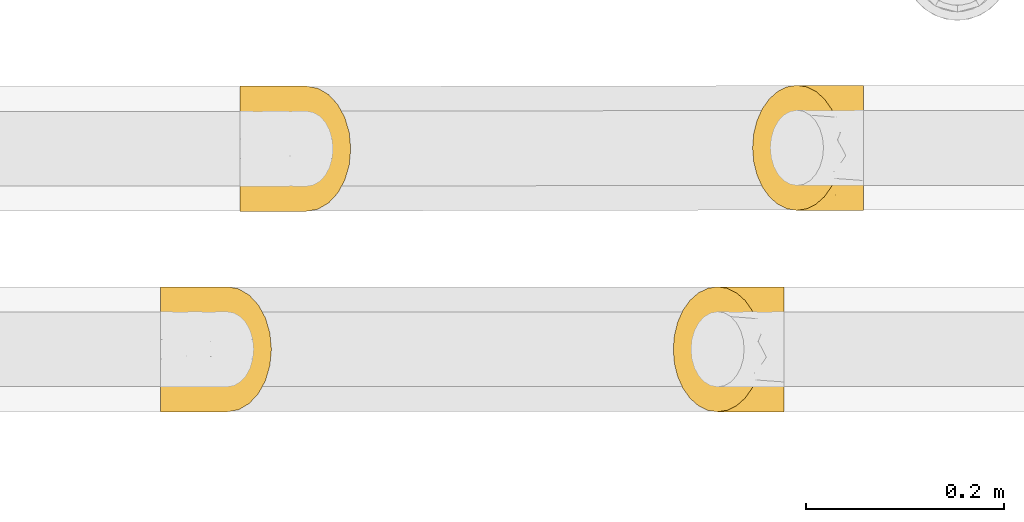
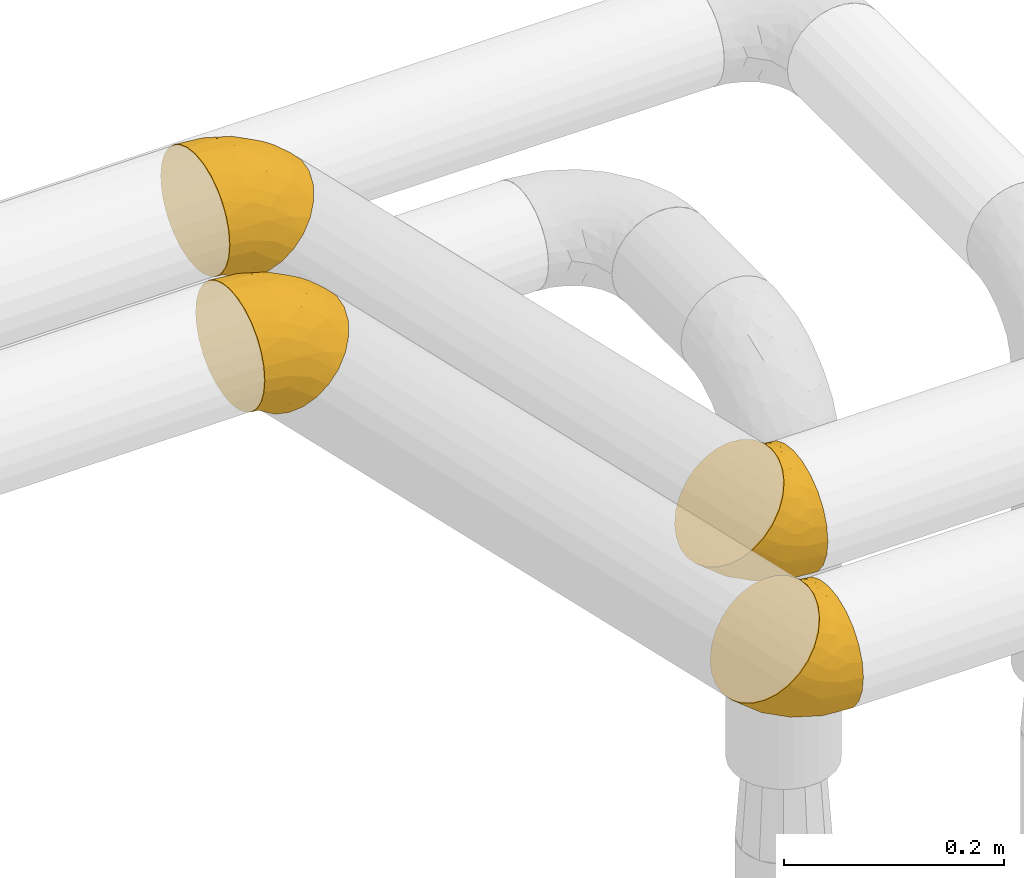
# One storey, part 406 of 827: 4 coverings.
"""IFC2X3 building model written with IfcOpenShell, lengths in millimetres."""

from ifc_helpers import new_model, entity, si_unit, converted_unit, derived_unit, direction, frame, origin, place, context, subcontext, project, spatial, faceted_brep, element, save


model = new_model("IFC2X3")

# Units and contexts
model_context = context("Model", 3, precision=0.01, world=origin(), true_north=direction((6.12303176911189e-17, 1.0)))
body_context = subcontext(model_context, "Body", "Model", "MODEL_VIEW")
ifc_project = project(units=[si_unit("LENGTHUNIT", "METRE", prefix="MILLI"), si_unit("AREAUNIT", "SQUARE_METRE"), si_unit("VOLUMEUNIT", "CUBIC_METRE"), converted_unit("PLANEANGLEUNIT", "DEGREE", entity("IfcRatioMeasure", 0.0174532925199433), si_unit("PLANEANGLEUNIT", "RADIAN"), dimensions=[0, 0, 0, 0, 0, 0, 0]), si_unit("MASSUNIT", "GRAM", prefix="KILO"), derived_unit("MASSDENSITYUNIT", [(si_unit("MASSUNIT", "GRAM", prefix="KILO"), 1), (si_unit("LENGTHUNIT", "METRE"), -3)]), derived_unit("MOMENTOFINERTIAUNIT", [(si_unit("LENGTHUNIT", "METRE"), 4)]), si_unit("TIMEUNIT", "SECOND"), si_unit("FREQUENCYUNIT", "HERTZ"), si_unit("THERMODYNAMICTEMPERATUREUNIT", "DEGREE_CELSIUS"), derived_unit("THERMALTRANSMITTANCEUNIT", [(si_unit("MASSUNIT", "GRAM", prefix="KILO"), 1), (si_unit("THERMODYNAMICTEMPERATUREUNIT", "KELVIN"), -1), (si_unit("TIMEUNIT", "SECOND"), -3)]), derived_unit("VOLUMETRICFLOWRATEUNIT", [(si_unit("LENGTHUNIT", "METRE"), 3), (si_unit("TIMEUNIT", "SECOND"), -1)]), derived_unit("MASSFLOWRATEUNIT", [(si_unit("MASSUNIT", "GRAM", prefix="KILO"), 1), (si_unit("TIMEUNIT", "SECOND"), -1)]), derived_unit("ROTATIONALFREQUENCYUNIT", [(si_unit("TIMEUNIT", "SECOND"), -1)]), si_unit("ELECTRICCURRENTUNIT", "AMPERE"), si_unit("ELECTRICVOLTAGEUNIT", "VOLT"), si_unit("POWERUNIT", "WATT"), si_unit("FORCEUNIT", "NEWTON", prefix="KILO"), si_unit("ILLUMINANCEUNIT", "LUX"), si_unit("LUMINOUSFLUXUNIT", "LUMEN"), si_unit("LUMINOUSINTENSITYUNIT", "CANDELA"), derived_unit("USERDEFINED", [(si_unit("MASSUNIT", "GRAM", prefix="KILO"), -1), (si_unit("LENGTHUNIT", "METRE"), -2), (si_unit("TIMEUNIT", "SECOND"), 3), (si_unit("LUMINOUSFLUXUNIT", "LUMEN"), 1)]), derived_unit("LINEARVELOCITYUNIT", [(si_unit("LENGTHUNIT", "METRE"), 1), (si_unit("TIMEUNIT", "SECOND"), -1)]), si_unit("PRESSUREUNIT", "PASCAL"), derived_unit("USERDEFINED", [(si_unit("LENGTHUNIT", "METRE"), -2), (si_unit("MASSUNIT", "GRAM", prefix="KILO"), 1), (si_unit("TIMEUNIT", "SECOND"), -2)]), derived_unit("LINEARFORCEUNIT", [(si_unit("MASSUNIT", "GRAM", prefix="KILO"), 1), (si_unit("LENGTHUNIT", "METRE"), 1), (si_unit("TIMEUNIT", "SECOND"), -2), (si_unit("LENGTHUNIT", "METRE"), -1)]), derived_unit("PLANARFORCEUNIT", [(si_unit("MASSUNIT", "GRAM", prefix="KILO"), 1), (si_unit("LENGTHUNIT", "METRE"), 1), (si_unit("TIMEUNIT", "SECOND"), -2), (si_unit("LENGTHUNIT", "METRE"), -2)])], contexts=[model_context])

# Site, building, storey
site_placement = place(None, origin())
site = spatial("IfcSite", under=ifc_project, at=site_placement, CompositionType="ELEMENT")
building_placement = place(site_placement, origin())
building = spatial("IfcBuilding", under=site, at=building_placement, CompositionType="ELEMENT")
storey_placement = place(building_placement, frame((0.0, 0.0, 28200.0)))
storey = spatial("IfcBuildingStorey", under=building, at=storey_placement, Name="08", CompositionType="ELEMENT", Elevation=28200.0)

# Coverings
covering_1_placement = place(storey_placement, frame((46299.81, 18745.18, 2935.35)))
element("IfcCovering", 1, at=covering_1_placement, inside=storey, Name=":ADSK_", ObjectType=":ADSK_", PredefinedType="INSULATION", context=body_context, shape_type="Brep", body=[
    faceted_brep([(90.76, 64.65, 137.05), (89.64, 78.67, 135.94), (86.35, 92.0, 132.64), (81.04, 103.95, 127.33), (73.98, 113.94, 120.27), (65.52, 121.45, 111.82), (56.1, 126.11, 102.39), (46.18, 127.7, 92.47), (36.26, 126.11, 82.55), (26.84, 121.45, 73.13), (18.38, 113.94, 64.67), (11.32, 103.96, 57.61), (6.01, 92.0, 52.3), (2.71, 78.68, 49.01), (1.6, 64.65, 47.89), (2.71, 50.62, 49.0), (6.01, 37.29, 52.3), (11.32, 25.34, 57.61), (18.38, 15.35, 64.67), (26.83, 7.84, 73.12), (36.25, 3.18, 82.55), (46.18, 1.6, 92.47), (56.1, 3.18, 102.39), (65.52, 7.84, 111.81), (73.97, 15.35, 120.27), (81.03, 25.33, 127.33), (86.35, 37.29, 132.64), (89.64, 50.61, 135.93), (113.35, 64.65, 127.7), (113.35, 48.33, 125.55), (113.35, 33.12, 119.25), (113.35, 20.06, 109.23), (113.35, 10.04, 96.17), (113.35, 3.74, 80.96), (113.35, 1.6, 64.65), (113.35, 3.74, 48.33), (113.35, 10.04, 33.12), (113.35, 20.06, 20.06), (113.35, 33.12, 10.04), (113.35, 48.33, 3.74), (113.35, 64.65, 1.6), (113.35, 80.96, 3.74), (113.35, 96.17, 10.04), (113.35, 109.23, 20.06), (113.35, 119.25, 33.12), (113.35, 125.55, 48.33), (113.35, 127.7, 64.65), (113.35, 125.55, 80.96), (113.35, 119.25, 96.17), (113.35, 109.23, 109.23), (113.35, 96.17, 119.25), (113.35, 80.96, 125.55), (38.33, 108.1, 40.64), (72.45, 64.65, 6.98), (88.64, 80.19, 5.51), (85.24, 102.05, 16.63), (34.33, 64.65, 22.77), (64.81, 81.27, 11.58), (69.69, 124.73, 54.22), (90.69, 122.26, 41.18), (31.06, 84.6, 28.52), (68.13, 113.02, 31.98), (88.77, 127.7, 67.88), (100.89, 127.7, 66.29), (28.58, 97.32, 37.21), (55.3, 96.3, 21.84), (42.37, 117.12, 50.8), (85.95, 90.52, 9.63), (56.15, 127.7, 84.82), (65.85, 127.7, 77.37), (77.31, 127.7, 72.63), (65.66, 119.88, 43.67), (75.33, 120.26, 106.56), (66.74, 125.9, 94.56), (99.0, 125.09, 83.93), (98.86, 117.94, 100.08), (85.36, 112.32, 113.78), (82.96, 122.53, 96.59), (95.92, 102.2, 118.86), (104.89, 105.16, 113.73), (95.15, 111.58, 109.97), (88.71, 99.98, 124.68), (106.15, 74.42, 127.74), (97.19, 87.77, 127.09), (97.31, 75.98, 130.83), (75.77, 126.59, 85.39), (87.36, 125.61, 85.14), (105.91, 90.37, 122.96), (101.13, 64.65, 130.13), (97.18, 41.51, 127.09), (85.35, 16.97, 113.78), (103.89, 52.07, 127.81), (98.85, 11.35, 100.08), (99.0, 4.2, 83.93), (104.07, 35.35, 121.59), (95.92, 27.09, 118.86), (100.89, 1.6, 66.29), (75.77, 2.7, 85.39), (65.85, 1.6, 77.37), (77.31, 1.6, 72.63), (75.33, 9.03, 106.56), (82.96, 6.76, 96.59), (86.65, 2.86, 81.66), (93.08, 6.13, 91.04), (104.89, 24.13, 113.73), (95.15, 17.7, 109.96), (66.74, 3.39, 94.56), (88.71, 29.31, 124.67), (56.15, 1.6, 84.82), (88.77, 1.6, 67.88), (69.69, 4.56, 54.22), (90.69, 7.03, 41.18), (38.33, 21.19, 40.64), (68.12, 16.27, 31.98), (42.36, 12.17, 50.8), (28.58, 31.97, 37.21), (55.3, 33.0, 21.84), (85.23, 27.24, 16.63), (88.64, 49.11, 5.51), (85.95, 38.77, 9.63), (31.06, 44.69, 28.52), (64.81, 48.02, 11.58), (65.66, 9.41, 43.67)], [[[0, 1, 2, 3, 4, 5, 6, 7, 8, 9, 10, 11, 12, 13, 14, 15, 16, 17, 18, 19, 20, 21, 22, 23, 24, 25, 26, 27]], [[28, 29, 30, 31, 32, 33, 34, 35, 36, 37, 38, 39, 40, 41, 42, 43, 44, 45, 46, 47, 48, 49, 50, 51]], [[52, 11, 10]], [[40, 53, 54]], [[42, 55, 43]], [[53, 56, 57]], [[9, 8, 58]], [[45, 59, 58]], [[56, 13, 60]], [[61, 44, 43]], [[45, 62, 63, 46]], [[62, 45, 58]], [[59, 45, 44]], [[64, 52, 65]], [[55, 61, 43]], [[61, 65, 52]], [[60, 57, 56]], [[60, 65, 57]], [[52, 10, 66]], [[64, 12, 11]], [[64, 60, 12]], [[13, 56, 14]], [[61, 55, 65]], [[67, 55, 42]], [[54, 67, 41]], [[61, 52, 66]], [[66, 10, 9]], [[8, 7, 68, 69]], [[58, 69, 70, 62]], [[58, 8, 69]], [[60, 64, 65]], [[52, 64, 11]], [[58, 59, 71]], [[54, 57, 67]], [[58, 66, 9]], [[60, 13, 12]], [[41, 67, 42]], [[65, 55, 67]], [[65, 67, 57]], [[40, 54, 41]], [[53, 57, 54]], [[44, 61, 59]], [[58, 71, 66]], [[59, 61, 71]], [[61, 66, 71]], [[72, 73, 5]], [[62, 74, 63]], [[48, 75, 49]], [[63, 74, 47]], [[75, 48, 74]], [[72, 76, 77]], [[78, 79, 80]], [[81, 3, 2]], [[82, 28, 51]], [[83, 84, 82]], [[73, 77, 85]], [[86, 62, 70]], [[83, 87, 78]], [[50, 87, 51]], [[86, 75, 74]], [[68, 73, 69]], [[5, 4, 72]], [[73, 6, 5]], [[74, 48, 47]], [[73, 68, 6]], [[80, 77, 76]], [[69, 85, 70]], [[81, 76, 3]], [[88, 84, 0]], [[84, 83, 1]], [[1, 83, 2]], [[3, 76, 4]], [[50, 49, 79]], [[83, 78, 81]], [[80, 76, 78]], [[73, 72, 77]], [[76, 72, 4]], [[85, 86, 70]], [[68, 7, 6]], [[73, 85, 69]], [[86, 85, 77]], [[75, 86, 77]], [[86, 74, 62]], [[47, 46, 63]], [[83, 81, 2]], [[76, 81, 78]], [[75, 79, 49]], [[87, 79, 78]], [[79, 75, 80]], [[77, 80, 75]], [[0, 84, 1]], [[82, 84, 88]], [[28, 82, 88]], [[82, 51, 87]], [[87, 50, 79]], [[82, 87, 83]], [[27, 26, 89]], [[25, 24, 90]], [[88, 91, 28]], [[32, 92, 93]], [[94, 89, 95]], [[94, 29, 91]], [[93, 96, 33]], [[97, 98, 99]], [[24, 23, 100]], [[101, 102, 103]], [[104, 95, 105]], [[93, 33, 32]], [[100, 90, 24]], [[102, 97, 99]], [[91, 27, 89]], [[97, 106, 98]], [[26, 107, 89]], [[93, 92, 103]], [[90, 95, 107]], [[31, 92, 32]], [[31, 30, 104]], [[107, 26, 25]], [[23, 22, 106]], [[101, 97, 102]], [[89, 94, 91]], [[31, 104, 92]], [[98, 106, 108]], [[106, 22, 108]], [[100, 106, 101]], [[101, 92, 105]], [[106, 100, 23]], [[27, 88, 0]], [[90, 100, 101]], [[22, 21, 108]], [[93, 102, 109]], [[106, 97, 101]], [[109, 102, 99]], [[102, 93, 103]], [[96, 93, 109]], [[96, 34, 33]], [[101, 103, 92]], [[90, 107, 25]], [[89, 107, 95]], [[94, 104, 30]], [[95, 90, 105]], [[101, 105, 90]], [[92, 104, 105]], [[104, 94, 95]], [[29, 94, 30]], [[28, 91, 29]], [[27, 91, 88]], [[35, 110, 111]], [[112, 113, 114]], [[35, 34, 96, 109]], [[112, 114, 18]], [[112, 115, 116]], [[117, 113, 116]], [[39, 118, 40]], [[116, 119, 117]], [[120, 121, 116]], [[113, 117, 37]], [[36, 113, 37]], [[38, 117, 119]], [[119, 116, 121]], [[20, 19, 110]], [[110, 109, 99, 98]], [[122, 111, 110]], [[20, 98, 108, 21]], [[37, 117, 38]], [[112, 18, 17]], [[39, 119, 118]], [[116, 113, 112]], [[110, 35, 109]], [[119, 39, 38]], [[114, 19, 18]], [[121, 120, 56]], [[115, 17, 16]], [[15, 14, 56]], [[15, 56, 120]], [[110, 19, 114]], [[115, 120, 116]], [[121, 56, 53]], [[15, 120, 16]], [[115, 112, 17]], [[20, 110, 98]], [[120, 115, 16]], [[35, 111, 36]], [[119, 121, 118]], [[121, 53, 118]], [[40, 118, 53]], [[122, 110, 114]], [[113, 36, 111]], [[114, 113, 122]], [[113, 111, 122]]]),
])
covering_2_placement = place(storey_placement, frame((45782.87, 18744.23, 3476.0)))
element("IfcCovering", 2, at=covering_2_placement, inside=storey, Name=":ADSK_", ObjectType=":ADSK_", PredefinedType="INSULATION", context=body_context, shape_type="Brep", body=[
    faceted_brep([(1.6, 64.76, 10.95), (1.6, 50.73, 12.51), (1.6, 37.4, 17.14), (1.6, 25.43, 24.63), (1.6, 15.43, 34.6), (1.6, 7.89, 46.54), (1.6, 3.2, 59.85), (1.6, 1.6, 73.88), (1.6, 3.15, 87.92), (1.6, 7.79, 101.25), (1.6, 15.28, 113.22), (1.6, 25.24, 123.22), (1.6, 37.18, 130.76), (1.6, 50.5, 135.44), (1.6, 64.53, 137.05), (1.6, 78.56, 135.5), (1.6, 91.89, 130.86), (1.6, 103.86, 123.37), (1.6, 113.86, 113.41), (1.6, 121.4, 101.47), (1.6, 126.09, 88.15), (1.6, 127.7, 74.12), (1.6, 126.14, 60.09), (1.6, 121.5, 46.76), (1.6, 114.01, 34.79), (1.6, 104.05, 24.78), (1.6, 92.11, 17.25), (1.6, 78.79, 12.56), (24.19, 64.78, 1.6), (25.71, 81.1, 3.15), (30.17, 96.29, 7.63), (37.25, 109.34, 14.74), (46.49, 119.34, 23.99), (57.24, 125.62, 34.75), (68.78, 127.74, 46.3), (80.32, 125.57, 57.83), (91.07, 119.25, 68.57), (100.3, 109.21, 77.79), (107.39, 96.14, 84.85), (111.84, 80.93, 89.27), (113.36, 64.61, 90.76), (111.84, 48.29, 89.21), (107.38, 33.09, 84.73), (100.3, 20.05, 77.62), (91.06, 10.05, 68.37), (80.31, 3.77, 57.6), (68.77, 1.64, 46.06), (57.23, 3.81, 34.52), (46.48, 10.13, 23.78), (37.25, 20.17, 14.57), (30.16, 33.24, 7.51), (25.71, 48.46, 3.08), (32.7, 21.11, 116.12), (80.62, 64.56, 115.88), (93.12, 49.04, 105.44), (82.84, 27.18, 99.94), (42.51, 64.53, 131.67), (71.97, 47.93, 117.99), (45.26, 4.54, 84.31), (69.34, 7.02, 78.68), (36.12, 44.58, 129.88), (59.89, 16.22, 101.16), (49.1, 1.62, 61.16), (58.8, 1.63, 53.71), (28.23, 31.87, 125.46), (57.99, 32.91, 117.43), (28.36, 12.1, 106.07), (88.3, 38.71, 104.41), (14.06, 1.6, 72.24), (26.18, 1.6, 70.65), (37.64, 1.61, 65.9), (49.88, 9.36, 94.63), (12.25, 9.09, 43.32), (14.66, 3.42, 57.87), (44.99, 4.26, 42.58), (33.47, 11.43, 31.27), (14.23, 17.05, 31.14), (24.69, 6.82, 44.97), (18.11, 27.19, 20.1), (28.08, 24.23, 17.38), (23.85, 17.79, 26.91), (8.9, 29.41, 21.09), (19.07, 55.0, 6.64), (13.18, 41.63, 13.41), (10.63, 53.43, 10.7), (27.52, 2.73, 57.97), (35.9, 3.73, 49.95), (22.27, 39.04, 10.17), (13.83, 64.77, 8.52), (13.19, 87.89, 13.5), (14.24, 112.4, 31.33), (17.42, 77.34, 8.23), (33.47, 118.02, 31.48), (45.0, 125.15, 42.8), (21.94, 94.05, 12.53), (18.11, 102.3, 20.24), (58.81, 127.73, 53.95), (27.53, 126.61, 58.2), (26.19, 127.7, 70.88), (37.65, 127.71, 66.14), (12.25, 120.32, 43.53), (24.7, 122.58, 45.19), (37.86, 126.47, 53.14), (35.78, 123.22, 41.96), (28.08, 105.27, 17.53), (23.86, 111.68, 27.09), (14.67, 125.93, 58.11), (8.9, 100.08, 21.22), (14.06, 127.7, 72.48), (49.1, 127.72, 61.39), (45.27, 124.71, 84.54), (69.35, 122.25, 78.9), (32.7, 108.02, 116.29), (59.89, 112.96, 101.35), (28.37, 117.06, 106.27), (28.23, 97.22, 125.59), (57.99, 96.21, 117.56), (82.85, 102.0, 100.08), (93.12, 80.12, 105.5), (88.3, 90.46, 104.51), (36.13, 84.49, 129.95), (71.97, 81.18, 118.06), (49.88, 119.84, 94.84)], [[[0, 1, 2, 3, 4, 5, 6, 7, 8, 9, 10, 11, 12, 13, 14, 15, 16, 17, 18, 19, 20, 21, 22, 23, 24, 25, 26, 27]], [[28, 29, 30, 31, 32, 33, 34, 35, 36, 37, 38, 39, 40, 41, 42, 43, 44, 45, 46, 47, 48, 49, 50, 51]], [[52, 11, 10]], [[40, 53, 54]], [[42, 55, 43]], [[53, 56, 57]], [[9, 8, 58]], [[45, 59, 58]], [[56, 13, 60]], [[61, 44, 43]], [[45, 62, 63, 46]], [[62, 45, 58]], [[59, 45, 44]], [[64, 52, 65]], [[55, 61, 43]], [[61, 65, 52]], [[60, 57, 56]], [[60, 65, 57]], [[52, 10, 66]], [[64, 12, 11]], [[64, 60, 12]], [[13, 56, 14]], [[61, 55, 65]], [[67, 55, 42]], [[54, 67, 41]], [[61, 52, 66]], [[66, 10, 9]], [[8, 7, 68, 69]], [[58, 69, 70, 62]], [[58, 8, 69]], [[60, 64, 65]], [[52, 64, 11]], [[58, 59, 71]], [[54, 57, 67]], [[58, 66, 9]], [[60, 13, 12]], [[41, 67, 42]], [[65, 55, 67]], [[65, 67, 57]], [[40, 54, 41]], [[53, 57, 54]], [[44, 61, 59]], [[58, 71, 66]], [[59, 61, 71]], [[61, 66, 71]], [[72, 73, 5]], [[62, 74, 63]], [[48, 75, 49]], [[63, 74, 47]], [[75, 48, 74]], [[72, 76, 77]], [[78, 79, 80]], [[81, 3, 2]], [[82, 28, 51]], [[83, 84, 82]], [[73, 77, 85]], [[86, 62, 70]], [[83, 87, 78]], [[50, 87, 51]], [[86, 75, 74]], [[68, 73, 69]], [[5, 4, 72]], [[73, 6, 5]], [[74, 48, 47]], [[73, 68, 6]], [[80, 77, 76]], [[69, 85, 70]], [[81, 76, 3]], [[88, 84, 0]], [[84, 83, 1]], [[1, 83, 2]], [[3, 76, 4]], [[50, 49, 79]], [[83, 78, 81]], [[80, 76, 78]], [[73, 72, 77]], [[76, 72, 4]], [[85, 86, 70]], [[68, 7, 6]], [[73, 85, 69]], [[86, 85, 77]], [[75, 86, 77]], [[86, 74, 62]], [[47, 46, 63]], [[83, 81, 2]], [[76, 81, 78]], [[75, 79, 49]], [[87, 79, 78]], [[79, 75, 80]], [[77, 80, 75]], [[0, 84, 1]], [[82, 84, 88]], [[28, 82, 88]], [[82, 51, 87]], [[87, 50, 79]], [[82, 87, 83]], [[27, 26, 89]], [[25, 24, 90]], [[88, 91, 28]], [[32, 92, 93]], [[94, 89, 95]], [[94, 29, 91]], [[93, 96, 33]], [[97, 98, 99]], [[24, 23, 100]], [[101, 102, 103]], [[104, 95, 105]], [[93, 33, 32]], [[100, 90, 24]], [[102, 97, 99]], [[91, 27, 89]], [[97, 106, 98]], [[26, 107, 89]], [[93, 92, 103]], [[90, 95, 107]], [[31, 92, 32]], [[31, 30, 104]], [[107, 26, 25]], [[23, 22, 106]], [[101, 97, 102]], [[89, 94, 91]], [[31, 104, 92]], [[98, 106, 108]], [[106, 22, 108]], [[100, 106, 101]], [[101, 92, 105]], [[106, 100, 23]], [[27, 88, 0]], [[90, 100, 101]], [[22, 21, 108]], [[93, 102, 109]], [[106, 97, 101]], [[109, 102, 99]], [[102, 93, 103]], [[96, 93, 109]], [[96, 34, 33]], [[101, 103, 92]], [[90, 107, 25]], [[89, 107, 95]], [[94, 104, 30]], [[95, 90, 105]], [[101, 105, 90]], [[92, 104, 105]], [[104, 94, 95]], [[29, 94, 30]], [[28, 91, 29]], [[27, 91, 88]], [[35, 110, 111]], [[112, 113, 114]], [[35, 34, 96, 109]], [[112, 114, 18]], [[112, 115, 116]], [[117, 113, 116]], [[39, 118, 40]], [[116, 119, 117]], [[120, 121, 116]], [[113, 117, 37]], [[36, 113, 37]], [[38, 117, 119]], [[119, 116, 121]], [[20, 19, 110]], [[110, 109, 99, 98]], [[122, 111, 110]], [[20, 98, 108, 21]], [[37, 117, 38]], [[112, 18, 17]], [[39, 119, 118]], [[116, 113, 112]], [[110, 35, 109]], [[119, 39, 38]], [[114, 19, 18]], [[121, 120, 56]], [[115, 17, 16]], [[15, 14, 56]], [[15, 56, 120]], [[110, 19, 114]], [[115, 120, 116]], [[121, 56, 53]], [[15, 120, 16]], [[115, 112, 17]], [[20, 110, 98]], [[120, 115, 16]], [[35, 111, 36]], [[119, 121, 118]], [[121, 53, 118]], [[40, 118, 53]], [[122, 110, 114]], [[113, 36, 111]], [[114, 113, 122]], [[113, 111, 122]]]),
])
covering_3_placement = place(storey_placement, frame((46219.82, 18542.05, 2935.35)))
element("IfcCovering", 3, at=covering_3_placement, inside=storey, Name=":ADSK_", ObjectType=":ADSK_", PredefinedType="INSULATION", context=body_context, shape_type="Brep", body=[
    faceted_brep([(90.76, 64.65, 137.05), (89.64, 78.67, 135.94), (86.35, 92.0, 132.64), (81.04, 103.95, 127.33), (73.98, 113.94, 120.27), (65.52, 121.45, 111.82), (56.1, 126.11, 102.39), (46.18, 127.7, 92.47), (36.26, 126.11, 82.55), (26.84, 121.45, 73.13), (18.38, 113.94, 64.67), (11.32, 103.96, 57.61), (6.01, 92.0, 52.3), (2.71, 78.68, 49.01), (1.6, 64.65, 47.89), (2.71, 50.62, 49.0), (6.01, 37.29, 52.3), (11.32, 25.34, 57.61), (18.38, 15.35, 64.67), (26.83, 7.84, 73.12), (36.25, 3.18, 82.55), (46.18, 1.6, 92.47), (56.1, 3.18, 102.39), (65.52, 7.84, 111.81), (73.97, 15.35, 120.27), (81.03, 25.33, 127.33), (86.35, 37.29, 132.64), (89.64, 50.61, 135.93), (113.35, 64.65, 127.7), (113.35, 48.33, 125.55), (113.35, 33.12, 119.25), (113.35, 20.06, 109.23), (113.35, 10.04, 96.17), (113.35, 3.74, 80.96), (113.35, 1.6, 64.65), (113.35, 3.74, 48.33), (113.35, 10.04, 33.12), (113.35, 20.06, 20.06), (113.35, 33.12, 10.04), (113.35, 48.33, 3.74), (113.35, 64.65, 1.6), (113.35, 80.96, 3.74), (113.35, 96.17, 10.04), (113.35, 109.23, 20.06), (113.35, 119.25, 33.12), (113.35, 125.55, 48.33), (113.35, 127.7, 64.65), (113.35, 125.55, 80.96), (113.35, 119.25, 96.17), (113.35, 109.23, 109.23), (113.35, 96.17, 119.25), (113.35, 80.96, 125.55), (38.33, 108.1, 40.64), (72.45, 64.65, 6.98), (88.64, 80.19, 5.51), (85.24, 102.05, 16.63), (34.33, 64.65, 22.77), (64.81, 81.27, 11.58), (69.69, 124.73, 54.22), (90.69, 122.26, 41.18), (31.06, 84.6, 28.52), (68.13, 113.02, 31.98), (88.77, 127.7, 67.88), (100.89, 127.7, 66.29), (28.58, 97.32, 37.21), (55.3, 96.3, 21.84), (42.37, 117.12, 50.8), (85.95, 90.52, 9.63), (56.15, 127.7, 84.82), (65.85, 127.7, 77.37), (77.31, 127.7, 72.63), (65.66, 119.88, 43.67), (75.33, 120.26, 106.56), (66.74, 125.9, 94.56), (99.0, 125.09, 83.93), (98.86, 117.94, 100.08), (85.36, 112.32, 113.78), (82.96, 122.53, 96.59), (95.92, 102.2, 118.86), (104.89, 105.16, 113.73), (95.15, 111.58, 109.97), (88.71, 99.98, 124.68), (106.15, 74.42, 127.74), (97.19, 87.77, 127.09), (97.31, 75.98, 130.83), (75.77, 126.59, 85.39), (87.36, 125.61, 85.14), (105.91, 90.37, 122.96), (101.13, 64.65, 130.13), (97.18, 41.51, 127.09), (85.35, 16.97, 113.78), (103.89, 52.07, 127.81), (98.85, 11.35, 100.08), (99.0, 4.2, 83.93), (104.07, 35.35, 121.59), (95.92, 27.09, 118.86), (100.89, 1.6, 66.29), (75.77, 2.7, 85.39), (65.85, 1.6, 77.37), (77.31, 1.6, 72.63), (75.33, 9.03, 106.56), (82.96, 6.76, 96.59), (86.65, 2.86, 81.66), (93.08, 6.13, 91.04), (104.89, 24.13, 113.73), (95.15, 17.7, 109.96), (66.74, 3.39, 94.56), (88.71, 29.31, 124.67), (56.15, 1.6, 84.82), (88.77, 1.6, 67.88), (69.69, 4.56, 54.22), (90.69, 7.03, 41.18), (38.33, 21.19, 40.64), (68.12, 16.27, 31.98), (42.36, 12.17, 50.8), (28.58, 31.97, 37.21), (55.3, 33.0, 21.84), (85.23, 27.24, 16.63), (88.64, 49.11, 5.51), (85.95, 38.77, 9.63), (31.06, 44.69, 28.52), (64.81, 48.02, 11.58), (65.66, 9.41, 43.67)], [[[0, 1, 2, 3, 4, 5, 6, 7, 8, 9, 10, 11, 12, 13, 14, 15, 16, 17, 18, 19, 20, 21, 22, 23, 24, 25, 26, 27]], [[28, 29, 30, 31, 32, 33, 34, 35, 36, 37, 38, 39, 40, 41, 42, 43, 44, 45, 46, 47, 48, 49, 50, 51]], [[52, 11, 10]], [[40, 53, 54]], [[42, 55, 43]], [[53, 56, 57]], [[9, 8, 58]], [[45, 59, 58]], [[56, 13, 60]], [[61, 44, 43]], [[45, 62, 63, 46]], [[62, 45, 58]], [[59, 45, 44]], [[64, 52, 65]], [[55, 61, 43]], [[61, 65, 52]], [[60, 57, 56]], [[60, 65, 57]], [[52, 10, 66]], [[64, 12, 11]], [[64, 60, 12]], [[13, 56, 14]], [[61, 55, 65]], [[67, 55, 42]], [[54, 67, 41]], [[61, 52, 66]], [[66, 10, 9]], [[8, 7, 68, 69]], [[58, 69, 70, 62]], [[58, 8, 69]], [[60, 64, 65]], [[52, 64, 11]], [[58, 59, 71]], [[54, 57, 67]], [[58, 66, 9]], [[60, 13, 12]], [[41, 67, 42]], [[65, 55, 67]], [[65, 67, 57]], [[40, 54, 41]], [[53, 57, 54]], [[44, 61, 59]], [[58, 71, 66]], [[59, 61, 71]], [[61, 66, 71]], [[72, 73, 5]], [[62, 74, 63]], [[48, 75, 49]], [[63, 74, 47]], [[75, 48, 74]], [[72, 76, 77]], [[78, 79, 80]], [[81, 3, 2]], [[82, 28, 51]], [[83, 84, 82]], [[73, 77, 85]], [[86, 62, 70]], [[83, 87, 78]], [[50, 87, 51]], [[86, 75, 74]], [[68, 73, 69]], [[5, 4, 72]], [[73, 6, 5]], [[74, 48, 47]], [[73, 68, 6]], [[80, 77, 76]], [[69, 85, 70]], [[81, 76, 3]], [[88, 84, 0]], [[84, 83, 1]], [[1, 83, 2]], [[3, 76, 4]], [[50, 49, 79]], [[83, 78, 81]], [[80, 76, 78]], [[73, 72, 77]], [[76, 72, 4]], [[85, 86, 70]], [[68, 7, 6]], [[73, 85, 69]], [[86, 85, 77]], [[75, 86, 77]], [[86, 74, 62]], [[47, 46, 63]], [[83, 81, 2]], [[76, 81, 78]], [[75, 79, 49]], [[87, 79, 78]], [[79, 75, 80]], [[77, 80, 75]], [[0, 84, 1]], [[82, 84, 88]], [[28, 82, 88]], [[82, 51, 87]], [[87, 50, 79]], [[82, 87, 83]], [[27, 26, 89]], [[25, 24, 90]], [[88, 91, 28]], [[32, 92, 93]], [[94, 89, 95]], [[94, 29, 91]], [[93, 96, 33]], [[97, 98, 99]], [[24, 23, 100]], [[101, 102, 103]], [[104, 95, 105]], [[93, 33, 32]], [[100, 90, 24]], [[102, 97, 99]], [[91, 27, 89]], [[97, 106, 98]], [[26, 107, 89]], [[93, 92, 103]], [[90, 95, 107]], [[31, 92, 32]], [[31, 30, 104]], [[107, 26, 25]], [[23, 22, 106]], [[101, 97, 102]], [[89, 94, 91]], [[31, 104, 92]], [[98, 106, 108]], [[106, 22, 108]], [[100, 106, 101]], [[101, 92, 105]], [[106, 100, 23]], [[27, 88, 0]], [[90, 100, 101]], [[22, 21, 108]], [[93, 102, 109]], [[106, 97, 101]], [[109, 102, 99]], [[102, 93, 103]], [[96, 93, 109]], [[96, 34, 33]], [[101, 103, 92]], [[90, 107, 25]], [[89, 107, 95]], [[94, 104, 30]], [[95, 90, 105]], [[101, 105, 90]], [[92, 104, 105]], [[104, 94, 95]], [[29, 94, 30]], [[28, 91, 29]], [[27, 91, 88]], [[35, 110, 111]], [[112, 113, 114]], [[35, 34, 96, 109]], [[112, 114, 18]], [[112, 115, 116]], [[117, 113, 116]], [[39, 118, 40]], [[116, 119, 117]], [[120, 121, 116]], [[113, 117, 37]], [[36, 113, 37]], [[38, 117, 119]], [[119, 116, 121]], [[20, 19, 110]], [[110, 109, 99, 98]], [[122, 111, 110]], [[20, 98, 108, 21]], [[37, 117, 38]], [[112, 18, 17]], [[39, 119, 118]], [[116, 113, 112]], [[110, 35, 109]], [[119, 39, 38]], [[114, 19, 18]], [[121, 120, 56]], [[115, 17, 16]], [[15, 14, 56]], [[15, 56, 120]], [[110, 19, 114]], [[115, 120, 116]], [[121, 56, 53]], [[15, 120, 16]], [[115, 112, 17]], [[20, 110, 98]], [[120, 115, 16]], [[35, 111, 36]], [[119, 121, 118]], [[121, 53, 118]], [[40, 118, 53]], [[122, 110, 114]], [[113, 36, 111]], [[114, 113, 122]], [[113, 111, 122]]]),
])
covering_4_placement = place(storey_placement, frame((45702.87, 18542.05, 3476.0)))
element("IfcCovering", 4, at=covering_4_placement, inside=storey, Name=":ADSK_", ObjectType=":ADSK_", PredefinedType="INSULATION", context=body_context, shape_type="Brep", body=[
    faceted_brep([(1.6, 64.65, 10.95), (1.6, 50.62, 12.53), (1.6, 37.29, 17.2), (1.6, 25.34, 24.71), (1.6, 15.35, 34.69), (1.6, 7.84, 46.64), (1.6, 3.18, 59.97), (1.6, 1.6, 74.0), (1.6, 3.18, 88.03), (1.6, 7.84, 101.36), (1.6, 15.35, 113.31), (1.6, 25.33, 123.3), (1.6, 37.29, 130.81), (1.6, 50.61, 135.47), (1.6, 64.65, 137.05), (1.6, 78.67, 135.47), (1.6, 92.0, 130.81), (1.6, 103.95, 123.3), (1.6, 113.94, 113.32), (1.6, 121.45, 101.36), (1.6, 126.11, 88.04), (1.6, 127.7, 74.0), (1.6, 126.11, 59.97), (1.6, 121.45, 46.65), (1.6, 113.94, 34.69), (1.6, 103.96, 24.71), (1.6, 92.0, 17.2), (1.6, 78.68, 12.53), (24.19, 64.65, 1.6), (25.71, 80.96, 3.11), (30.16, 96.17, 7.57), (37.25, 109.23, 14.65), (46.48, 119.25, 23.89), (57.23, 125.55, 34.64), (68.77, 127.7, 46.18), (80.31, 125.55, 57.72), (91.06, 119.25, 68.47), (100.3, 109.23, 77.7), (107.38, 96.17, 84.79), (111.83, 80.96, 89.24), (113.35, 64.65, 90.76), (111.83, 48.33, 89.24), (107.38, 33.12, 84.79), (100.3, 20.06, 77.7), (91.06, 10.04, 68.47), (80.31, 3.74, 57.72), (68.77, 1.6, 46.18), (57.23, 3.74, 34.64), (46.48, 10.04, 23.89), (37.25, 20.06, 14.65), (30.16, 33.12, 7.57), (25.71, 48.33, 3.11), (32.7, 21.19, 116.2), (80.62, 64.65, 115.88), (93.11, 49.11, 105.47), (82.84, 27.24, 100.01), (42.5, 64.65, 131.67), (71.97, 48.02, 118.02), (45.26, 4.56, 84.43), (69.34, 7.03, 78.79), (36.12, 44.69, 129.91), (59.89, 16.27, 101.26), (49.1, 1.6, 61.28), (58.8, 1.6, 53.83), (28.22, 31.97, 125.53), (57.99, 33.0, 117.49), (28.36, 12.17, 106.16), (88.29, 38.77, 104.46), (14.06, 1.6, 72.36), (26.18, 1.6, 70.77), (37.64, 1.6, 66.02), (49.88, 9.41, 94.73), (12.25, 9.03, 43.42), (14.66, 3.39, 57.99), (44.99, 4.2, 42.69), (33.47, 11.35, 31.37), (14.23, 16.97, 31.23), (24.69, 6.76, 45.08), (18.1, 27.09, 20.17), (28.08, 24.13, 17.46), (23.85, 17.71, 27.0), (8.9, 29.31, 21.15), (19.06, 54.87, 6.66), (13.18, 41.52, 13.45), (10.63, 53.31, 10.72), (27.52, 2.7, 58.08), (35.9, 3.68, 50.06), (22.27, 38.92, 10.21), (13.82, 64.65, 8.52), (13.18, 87.78, 13.45), (14.23, 112.32, 31.24), (17.42, 77.22, 8.21), (33.46, 117.94, 31.38), (44.99, 125.09, 42.69), (21.94, 93.94, 12.47), (18.11, 102.2, 20.17), (58.8, 127.7, 53.83), (27.53, 126.59, 58.09), (26.18, 127.7, 70.77), (37.64, 127.7, 66.02), (12.25, 120.26, 43.43), (24.69, 122.53, 45.08), (37.86, 126.43, 53.03), (35.77, 123.17, 41.85), (28.08, 105.16, 17.46), (23.85, 111.59, 27.0), (14.66, 125.9, 57.99), (8.9, 99.98, 21.16), (14.06, 127.7, 72.36), (49.1, 127.7, 61.28), (45.26, 124.73, 84.43), (69.34, 122.26, 78.79), (32.7, 108.1, 116.21), (59.88, 113.02, 101.26), (28.36, 117.12, 106.17), (28.23, 97.32, 125.53), (57.99, 96.29, 117.5), (82.84, 102.05, 100.01), (93.11, 80.18, 105.47), (88.29, 90.52, 104.46), (36.12, 84.6, 129.91), (71.97, 81.27, 118.03), (49.88, 119.88, 94.73)], [[[0, 1, 2, 3, 4, 5, 6, 7, 8, 9, 10, 11, 12, 13, 14, 15, 16, 17, 18, 19, 20, 21, 22, 23, 24, 25, 26, 27]], [[28, 29, 30, 31, 32, 33, 34, 35, 36, 37, 38, 39, 40, 41, 42, 43, 44, 45, 46, 47, 48, 49, 50, 51]], [[52, 11, 10]], [[40, 53, 54]], [[42, 55, 43]], [[53, 56, 57]], [[9, 8, 58]], [[45, 59, 58]], [[56, 13, 60]], [[61, 44, 43]], [[45, 62, 63, 46]], [[62, 45, 58]], [[59, 45, 44]], [[64, 52, 65]], [[55, 61, 43]], [[61, 65, 52]], [[60, 57, 56]], [[60, 65, 57]], [[52, 10, 66]], [[64, 12, 11]], [[64, 60, 12]], [[13, 56, 14]], [[61, 55, 65]], [[67, 55, 42]], [[54, 67, 41]], [[61, 52, 66]], [[66, 10, 9]], [[8, 7, 68, 69]], [[58, 69, 70, 62]], [[58, 8, 69]], [[60, 64, 65]], [[52, 64, 11]], [[58, 59, 71]], [[54, 57, 67]], [[58, 66, 9]], [[60, 13, 12]], [[41, 67, 42]], [[65, 55, 67]], [[65, 67, 57]], [[40, 54, 41]], [[53, 57, 54]], [[44, 61, 59]], [[58, 71, 66]], [[59, 61, 71]], [[61, 66, 71]], [[72, 73, 5]], [[62, 74, 63]], [[48, 75, 49]], [[63, 74, 47]], [[75, 48, 74]], [[72, 76, 77]], [[78, 79, 80]], [[81, 3, 2]], [[82, 28, 51]], [[83, 84, 82]], [[73, 77, 85]], [[86, 62, 70]], [[83, 87, 78]], [[50, 87, 51]], [[86, 75, 74]], [[68, 73, 69]], [[5, 4, 72]], [[73, 6, 5]], [[74, 48, 47]], [[73, 68, 6]], [[80, 77, 76]], [[69, 85, 70]], [[81, 76, 3]], [[88, 84, 0]], [[84, 83, 1]], [[1, 83, 2]], [[3, 76, 4]], [[50, 49, 79]], [[83, 78, 81]], [[80, 76, 78]], [[73, 72, 77]], [[76, 72, 4]], [[85, 86, 70]], [[68, 7, 6]], [[73, 85, 69]], [[86, 85, 77]], [[75, 86, 77]], [[86, 74, 62]], [[47, 46, 63]], [[83, 81, 2]], [[76, 81, 78]], [[75, 79, 49]], [[87, 79, 78]], [[79, 75, 80]], [[77, 80, 75]], [[0, 84, 1]], [[82, 84, 88]], [[28, 82, 88]], [[82, 51, 87]], [[87, 50, 79]], [[82, 87, 83]], [[27, 26, 89]], [[25, 24, 90]], [[88, 91, 28]], [[32, 92, 93]], [[94, 89, 95]], [[94, 29, 91]], [[93, 96, 33]], [[97, 98, 99]], [[24, 23, 100]], [[101, 102, 103]], [[104, 95, 105]], [[93, 33, 32]], [[100, 90, 24]], [[102, 97, 99]], [[91, 27, 89]], [[97, 106, 98]], [[26, 107, 89]], [[93, 92, 103]], [[90, 95, 107]], [[31, 92, 32]], [[31, 30, 104]], [[107, 26, 25]], [[23, 22, 106]], [[101, 97, 102]], [[89, 94, 91]], [[31, 104, 92]], [[98, 106, 108]], [[106, 22, 108]], [[100, 106, 101]], [[101, 92, 105]], [[106, 100, 23]], [[27, 88, 0]], [[90, 100, 101]], [[22, 21, 108]], [[93, 102, 109]], [[106, 97, 101]], [[109, 102, 99]], [[102, 93, 103]], [[96, 93, 109]], [[96, 34, 33]], [[101, 103, 92]], [[90, 107, 25]], [[89, 107, 95]], [[94, 104, 30]], [[95, 90, 105]], [[101, 105, 90]], [[92, 104, 105]], [[104, 94, 95]], [[29, 94, 30]], [[28, 91, 29]], [[27, 91, 88]], [[35, 110, 111]], [[112, 113, 114]], [[35, 34, 96, 109]], [[112, 114, 18]], [[112, 115, 116]], [[117, 113, 116]], [[39, 118, 40]], [[116, 119, 117]], [[120, 121, 116]], [[113, 117, 37]], [[36, 113, 37]], [[38, 117, 119]], [[119, 116, 121]], [[20, 19, 110]], [[110, 109, 99, 98]], [[122, 111, 110]], [[20, 98, 108, 21]], [[37, 117, 38]], [[112, 18, 17]], [[39, 119, 118]], [[116, 113, 112]], [[110, 35, 109]], [[119, 39, 38]], [[114, 19, 18]], [[121, 120, 56]], [[115, 17, 16]], [[15, 14, 56]], [[15, 56, 120]], [[110, 19, 114]], [[115, 120, 116]], [[121, 56, 53]], [[15, 120, 16]], [[115, 112, 17]], [[20, 110, 98]], [[120, 115, 16]], [[35, 111, 36]], [[119, 121, 118]], [[121, 53, 118]], [[40, 118, 53]], [[122, 110, 114]], [[113, 36, 111]], [[114, 113, 122]], [[113, 111, 122]]]),
])

save(model, "model.ifc")
